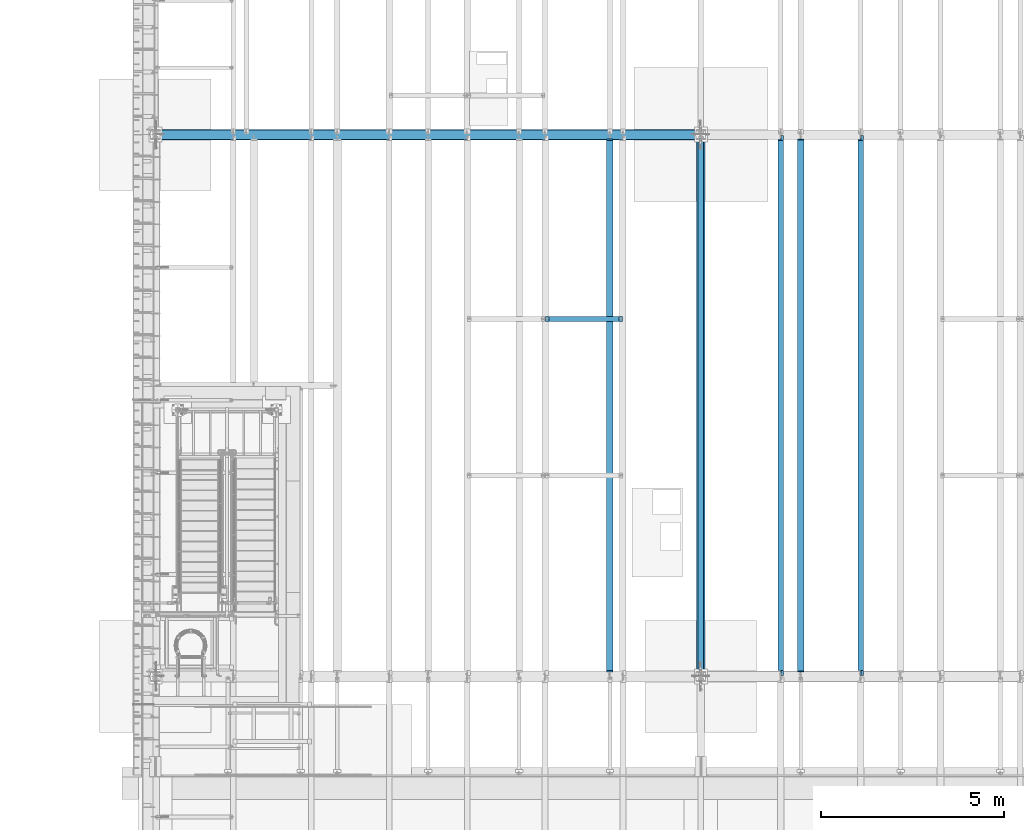
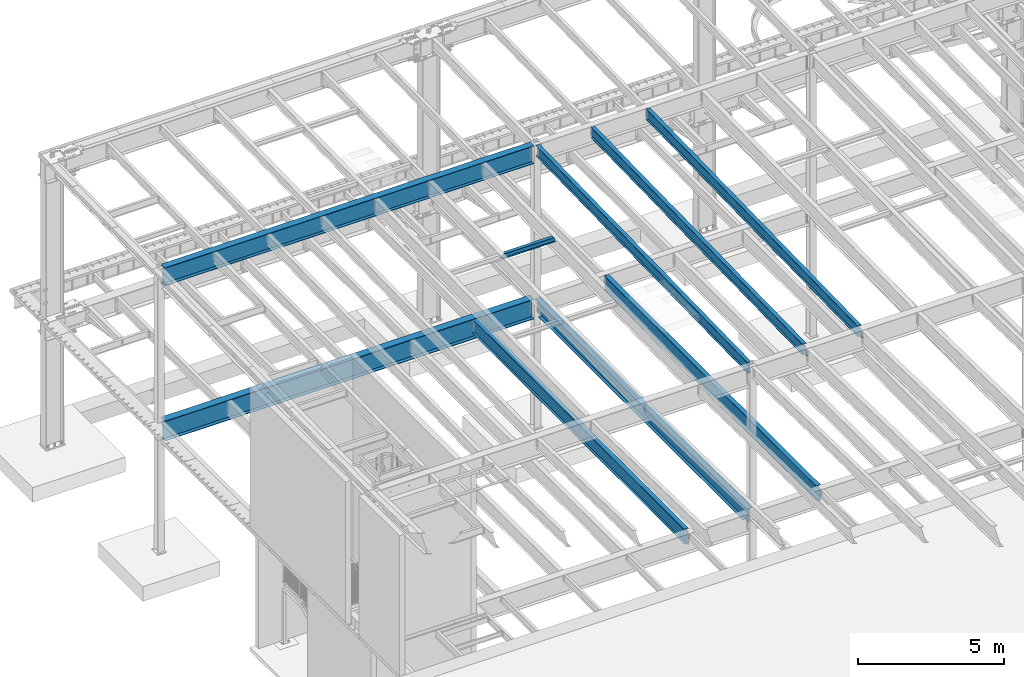
# One storey, part 1098 of 1763: 9 beams, 9 elements without a shape of their own.
"""IFC2X3 building model written with IfcOpenShell, lengths in millimetres."""

from ifc_helpers import new_model, si_unit, frame, origin_with_axes, place, context, subcontext, project, spatial, faceted_brep, material, type_object, element, aggregate, save


model = new_model("IFC2X3")

# Units and contexts
model_context = context("Model", 3, precision=1e-05, world=origin_with_axes())
body_context = subcontext(model_context, "Body", "Model", "MODEL_VIEW")
ifc_project = project(units=[si_unit("LENGTHUNIT", "METRE", prefix="MILLI"), si_unit("AREAUNIT", "SQUARE_METRE"), si_unit("VOLUMEUNIT", "CUBIC_METRE"), si_unit("MASSUNIT", "GRAM", prefix="KILO"), si_unit("TIMEUNIT", "SECOND"), si_unit("PLANEANGLEUNIT", "RADIAN"), si_unit("SOLIDANGLEUNIT", "STERADIAN"), si_unit("THERMODYNAMICTEMPERATUREUNIT", "DEGREE_CELSIUS"), si_unit("LUMINOUSINTENSITYUNIT", "LUMEN")], contexts=[model_context])

# Site, building, storey
site_placement = place(None, origin_with_axes())
site = spatial("IfcSite", under=ifc_project, at=site_placement, CompositionType="ELEMENT")
building_placement = place(site_placement, origin_with_axes())
building = spatial("IfcBuilding", under=site, at=building_placement, Name="Undefined", CompositionType="ELEMENT")
storey_placement = place(building_placement, origin_with_axes())
storey = spatial("IfcBuildingStorey", under=building, at=storey_placement, Name="Undefined", CompositionType="ELEMENT", Elevation=0.0)

# Assembly, beam
assembly_1_placement = place(storey_placement, origin_with_axes())
assembly_1 = element("IfcElementAssembly", 1, at=assembly_1_placement, inside=storey, Name="BEAM", AssemblyPlace="NOTDEFINED", PredefinedType="RIGID_FRAME")
ifc_material = material(Name="STEEL/A992")
beam_type_1 = type_object("IfcBeamType", Name="W8X18", PredefinedType="NOTDEFINED")
beam_1_placement = place(assembly_1_placement, frame((-76743.7229879841, 39776.4, 11388.9111170495), z_axis=(0.0, 0.0, 1.0), x_axis=(1.0, 0.0, 0.0)))
beam_1 = element("IfcBeam", 2, at=beam_1_placement, type_object=beam_type_1, material=ifc_material, Name="BEAM", ObjectType="W8X18", context=body_context, shape_type="Brep", body=[
    faceted_brep([(2030.05010096592, -3.17500000000018, 68.5472454972532), (2030.05010096592, 3.17500000000018, 68.5472454972532), (2029.18911617418, 3.17500000000291, 69.8358002989789), (2029.18911617418, -3.17500000000291, 69.8358002989789), (2034.17027743408, -3.17500000000018, 65.7942315967757), (2034.17027743408, 3.17500000000018, 65.7942315967757), (2039.03035695212, -3.17500000000018, 64.8275016741882), (2039.03035695212, 3.17500000000018, 64.8275016741882), (2108.88035714286, -3.17500000000018, 64.8275016741882), (2108.88035714286, 3.17500000000018, 64.8275016741882), (2028.46260401768, -3.17500000000291, 70.3212402021363), (2028.46260401768, 3.17500000000291, 70.3212402021363), (2025.7095901172, 3.17500000000291, 74.44141667029), (2025.7095901172, -3.17500000000291, 74.44141667029), (2024.74286019462, 3.17500000000291, 79.3014961883364), (2024.74286019462, -3.17500000000291, 79.3014961883364), (2024.74286019463, 66.6750000000002, 95.25), (2024.74286019463, 3.17500000000018, 95.25), (101.599996948244, 3.17500000000018, 95.25), (101.599996948244, 66.6750000000002, 95.25), (2024.74286019463, -66.6750000000002, 95.25), (2024.74286019463, -66.6750000000002, 103.1875), (101.599996948244, -66.6750000000002, 103.1875), (101.599996948244, -66.6750000000002, 95.25), (2024.74286019463, 66.6750000000002, 103.1875), (101.599996948244, 66.6750000000002, 103.1875), (2024.74286019463, -3.17500000000018, 95.25), (101.599996948244, -3.17500000000018, 95.25), (101.599996948236, 3.17499999999927, 79.301496189446), (101.599996948236, -3.17499999999927, 79.301496189446), (100.633267025652, 3.17499999999927, 74.4414166713996), (100.633267025652, -3.17499999999927, 74.4414166713996), (97.8802531251713, 3.17499999999927, 70.3212402032459), (97.8802531251713, -3.17499999999927, 70.3212402032459), (97.153740969894, 3.17499999999927, 69.8358003008998), (97.153740969894, -3.17499999999927, 69.8358003008998), (96.2927561769247, 3.17500000000018, 68.5472454911378), (96.2927561769247, -3.17500000000018, 68.5472454911378), (92.1725797087711, 3.17500000000018, 65.7942315906603), (92.1725797087711, -3.17500000000018, 65.7942315906603), (87.3125001907247, 3.17500000000018, 64.8275016680727), (87.3125001907247, -3.17500000000018, 64.8275016680727), (17.4624999999905, 3.17500000000018, 64.8275016680727), (17.4624999999905, -3.17500000000018, 64.8275016680727), (17.4624999999905, 3.17500000000018, -95.25), (17.4624999999905, 66.6750000000002, -95.25), (17.4624999999905, 66.6750000000002, -103.1875), (17.4624999999905, -66.6750000000002, -103.1875), (17.4624999999905, -66.6750000000002, -95.25), (17.4624999999905, -3.17500000000018, -95.25), (2108.88035714286, 3.17500000000018, -95.25), (2108.88035714286, 66.6750000000002, -95.25), (2108.88035714286, 66.6750000000002, -103.1875), (2108.88035714286, -66.6750000000002, -103.1875), (2108.88035714286, -66.6750000000002, -95.25), (2108.88035714286, -3.17500000000018, -95.25)], [[[0, 1, 2, 3]], [[4, 5, 1, 0]], [[6, 7, 5, 4]], [[8, 9, 7, 6]], [[10, 11, 12, 13]], [[13, 12, 14, 15]], [[16, 17, 18, 19]], [[20, 21, 22, 23]], [[21, 24, 25, 22]], [[24, 16, 19, 25]], [[21, 20, 26, 15, 14, 17, 16, 24]], [[26, 20, 23, 27]], [[22, 25, 19, 18, 28, 29, 27, 23]], [[29, 28, 30, 31]], [[31, 30, 32, 33]], [[33, 32, 34, 35]], [[35, 34, 36, 37]], [[37, 36, 38, 39]], [[39, 38, 40, 41]], [[41, 40, 42, 43]], [[44, 45, 46, 47, 48, 49, 43, 42]], [[45, 44, 50, 51]], [[46, 45, 51, 52]], [[47, 46, 52, 53]], [[48, 47, 53, 54]], [[49, 48, 54, 55]], [[4, 0, 3, 10, 13, 15, 26, 27, 29, 31, 33, 35, 37, 39, 41, 43, 49, 55, 8, 6]], [[11, 10, 3, 2]], [[50, 44, 42, 40, 38, 36, 34, 32, 30, 28, 18, 17, 14, 12, 11, 2, 1, 5, 7, 9]], [[55, 54, 53, 52, 51, 50, 9, 8]]]),
])
aggregate(assembly_1, [beam_1])

assembly_2_placement = place(storey_placement, origin_with_axes())
assembly_2 = element("IfcElementAssembly", 3, at=assembly_2_placement, inside=storey, Name="BEAM", AssemblyPlace="NOTDEFINED", PredefinedType="RIGID_FRAME")
beam_type_2 = type_object("IfcBeamType", Name="W18X35", PredefinedType="NOTDEFINED")
beam_2_placement = place(assembly_2_placement, frame((-68132.3972736984, 30027.4629676506, 11064.9232324289), z_axis=(0.0, -0.0206852279954837, 0.999786037781472), x_axis=(0.0, 0.999786037781472, 0.0206852279954825)))
beam_2 = element("IfcBeam", 4, at=beam_2_placement, type_object=beam_type_2, material=ifc_material, Name="BEAM", ObjectType="W18X35", context=body_context, shape_type="Brep", body=[
    faceted_brep([(148.534036706205, 4.26867060484074, -214.312499999867), (148.534036706187, 4.26882633028436, -225.424999999857), (10.5200655540102, 4.26881607816904, -225.424999999832), (10.7499793429743, 4.26866036980209, -214.312499999842), (148.534031383831, 76.1999999999971, -214.312499999869), (148.534031383828, 76.1999999999971, -225.424999999857), (161.234030986459, -3.96875, 187.065001487535), (161.234030986459, 3.96875, 187.065001487535), (160.267301063872, 3.96875, 182.204921969502), (160.267301063872, -3.96875, 182.204921969502), (157.514287163402, 3.96875, 178.084745501357), (157.514287163402, -3.96875, 178.084745501357), (153.394110695255, 3.96875, 175.331731600885), (153.394110695255, -3.96875, 175.331731600885), (148.534031177223, 3.96875, 174.365001678299), (148.534031177223, -3.96875, 174.365001678299), (18.7915826811914, 3.96875, 174.365001678325), (18.7915826811914, -3.96875, 174.365001678325), (10.7499793429743, -3.96875, -214.312499999842), (14757.8115434472, -3.96875, -214.312500002648), (14765.8531467846, -3.96875, 174.36500163611), (14641.5955948759, -3.96875, 174.365001636133), (14636.7355153579, -3.96875, 175.331731558719), (14632.6153388897, -3.96875, 178.084745459191), (14629.8623249892, -3.96875, 182.204921927336), (14628.8955950666, -3.96875, 187.065001445368), (14628.8955950666, -3.96875, 214.312499997053), (161.234030986467, -3.96875, 214.312499999809), (10.7499793429743, -76.1999999999971, -214.312499999842), (14757.8115434472, -76.1999999999971, -214.312500002648), (10.5200655540102, -76.1999999999971, -225.424999999832), (14757.5816296582, -76.1999999999971, -225.425000002639), (14641.5955921487, 4.26882640406257, -214.312500002627), (14641.5955921487, 4.26867068048159, -225.425000002617), (14641.5955830855, 76.1999999999971, -225.425000002617), (14641.5955830855, 76.1999999999971, -214.312500002628), (14757.8115434472, 4.26884104704368, -214.312500002648), (14757.5816296582, 4.26868529446074, -225.425000002639), (14757.8115434472, 3.96875, -214.312500002648), (14765.8531467846, 3.96875, 174.36500163611), (14641.5955948759, 3.96875, 174.365001636133), (14636.7355153579, 3.96875, 175.331731558719), (14632.6153388897, 3.96875, 178.084745459191), (14629.8623249892, 3.96875, 182.204921927336), (14628.8955950666, 3.96875, 187.065001445368), (14628.8955950666, -76.1999999999971, 225.424999997045), (14628.8955950666, -76.1999999999971, 214.312499997053), (14628.8955950666, 3.96875, 214.312499997053), (14628.8955950666, 76.1999999999971, 214.312499997053), (14628.8955950666, 76.1999999999971, 225.424999997045), (161.234030986467, 3.96875, 214.312499999809), (161.234030986467, 76.1999999999971, 214.312499999809), (161.23403098647, 76.1999999999971, 225.424999999799), (161.23403098647, -76.1999999999971, 225.424999999799), (161.234030986467, -76.1999999999971, 214.312499999809), (10.7499793429743, 3.96875, -214.312499999842)], [[[0, 1, 2, 3]], [[4, 5, 1, 0]], [[6, 7, 8, 9]], [[9, 8, 10, 11]], [[11, 10, 12, 13]], [[13, 12, 14, 15]], [[15, 14, 16, 17]], [[9, 11, 13, 15, 17, 18, 19, 20, 21, 22, 23, 24, 25, 26, 27, 6]], [[18, 28, 29, 19]], [[28, 30, 31, 29]], [[32, 33, 34, 35]], [[36, 37, 33, 32]], [[38, 39, 20, 19, 29, 31, 37, 36]], [[20, 39, 40, 21]], [[21, 40, 41, 22]], [[22, 41, 42, 23]], [[23, 42, 43, 24]], [[24, 43, 44, 25]], [[45, 46, 26, 25, 44, 47, 48, 49]], [[48, 47, 50, 51]], [[49, 48, 51, 52]], [[45, 49, 52, 53]], [[46, 45, 53, 54]], [[26, 46, 54, 27]], [[53, 52, 51, 50, 7, 6, 27, 54]], [[47, 44, 43, 42, 41, 40, 39, 38, 55, 16, 14, 12, 10, 8, 7, 50]], [[30, 28, 18, 17, 16, 55, 3, 2]], [[34, 33, 37, 31, 30, 2, 1, 5]], [[35, 34, 5, 4]], [[55, 38, 36, 32, 35, 4, 0, 3]]]),
])
aggregate(assembly_2, [beam_2])

assembly_3_placement = place(storey_placement, origin_with_axes())
assembly_3 = element("IfcElementAssembly", 5, at=assembly_3_placement, inside=storey, Name="BEAM", AssemblyPlace="NOTDEFINED", PredefinedType="RIGID_FRAME")
beam_3_placement = place(assembly_3_placement, frame((-70311.7172736983, 30027.4629676506, 11064.9232324289), z_axis=(0.0, -0.0206852279954837, 0.999786037781472), x_axis=(0.0, 0.999786037781472, 0.0206852279954825)))
beam_3 = element("IfcBeam", 6, at=beam_3_placement, type_object=beam_type_2, material=ifc_material, Name="BEAM", ObjectType="W18X35", context=body_context, shape_type="Brep", body=[
    faceted_brep([(161.234036217043, 4.26867060289806, -214.312499999869), (161.234036217025, 4.26882632687921, -225.424999999863), (10.5200655540102, 4.26881607816904, -225.424999999832), (10.7499793429743, 4.26866036980209, -214.312499999842), (161.234031325755, 76.1999999999971, -214.312499999867), (161.234031325748, 76.1999999999971, -225.424999999861), (161.234030986459, -3.96875, 187.065001487535), (161.234030986459, 3.96875, 187.065001487535), (160.267301063872, 3.96875, 182.204921969502), (160.267301063872, -3.96875, 182.204921969502), (157.514287163402, 3.96875, 178.084745501357), (157.514287163402, -3.96875, 178.084745501357), (153.394110695255, 3.96875, 175.331731600885), (153.394110695255, -3.96875, 175.331731600885), (148.534031177223, 3.96875, 174.365001678299), (148.534031177223, -3.96875, 174.365001678299), (18.7915826811914, 3.96875, 174.365001678325), (18.7915826811914, -3.96875, 174.365001678325), (10.7499793429743, -3.96875, -214.312499999842), (14757.8115434472, -3.96875, -214.312500002648), (14765.8531467846, -3.96875, 174.36500163611), (14641.5955948759, -3.96875, 174.365001636133), (14636.7355153579, -3.96875, 175.331731558719), (14632.6153388897, -3.96875, 178.084745459191), (14629.8623249892, -3.96875, 182.204921927336), (14628.8955950666, -3.96875, 187.065001445368), (14628.8955950666, -3.96875, 214.312499997053), (161.234030986467, -3.96875, 214.312499999809), (10.7499793429743, -76.1999999999971, -214.312499999842), (14757.8115434472, -76.1999999999971, -214.312500002648), (10.5200655540102, -76.1999999999971, -225.424999999832), (14757.5816296582, -76.1999999999971, -225.425000002639), (14641.5955921487, 4.26882640406257, -214.312500002627), (14641.5955921487, 4.26867068048159, -225.425000002617), (14641.5955830855, 76.1999999999971, -225.425000002617), (14641.5955830855, 76.1999999999971, -214.312500002628), (14757.8115434472, 4.26884104704368, -214.312500002648), (14757.5816296582, 4.26868529446074, -225.425000002639), (14757.8115434472, 3.96875, -214.312500002648), (14765.8531467846, 3.96875, 174.36500163611), (14641.5955948759, 3.96875, 174.365001636133), (14636.7355153579, 3.96875, 175.331731558719), (14632.6153388897, 3.96875, 178.084745459191), (14629.8623249892, 3.96875, 182.204921927336), (14628.8955950666, 3.96875, 187.065001445368), (14628.8955950666, -76.1999999999971, 225.424999997045), (14628.8955950666, -76.1999999999971, 214.312499997053), (14628.8955950666, 3.96875, 214.312499997053), (14628.8955950666, 76.1999999999971, 214.312499997053), (14628.8955950666, 76.1999999999971, 225.424999997045), (161.234030986467, 3.96875, 214.312499999809), (161.234030986467, 76.1999999999971, 214.312499999809), (161.23403098647, 76.1999999999971, 225.424999999799), (161.23403098647, -76.1999999999971, 225.424999999799), (161.234030986467, -76.1999999999971, 214.312499999809), (10.7499793429743, 3.96875, -214.312499999842)], [[[0, 1, 2, 3]], [[4, 5, 1, 0]], [[6, 7, 8, 9]], [[9, 8, 10, 11]], [[11, 10, 12, 13]], [[13, 12, 14, 15]], [[15, 14, 16, 17]], [[9, 11, 13, 15, 17, 18, 19, 20, 21, 22, 23, 24, 25, 26, 27, 6]], [[18, 28, 29, 19]], [[28, 30, 31, 29]], [[32, 33, 34, 35]], [[36, 37, 33, 32]], [[38, 39, 20, 19, 29, 31, 37, 36]], [[20, 39, 40, 21]], [[21, 40, 41, 22]], [[22, 41, 42, 23]], [[23, 42, 43, 24]], [[24, 43, 44, 25]], [[45, 46, 26, 25, 44, 47, 48, 49]], [[48, 47, 50, 51]], [[49, 48, 51, 52]], [[45, 49, 52, 53]], [[46, 45, 53, 54]], [[26, 46, 54, 27]], [[53, 52, 51, 50, 7, 6, 27, 54]], [[47, 44, 43, 42, 41, 40, 39, 38, 55, 16, 14, 12, 10, 8, 7, 50]], [[30, 28, 18, 17, 16, 55, 3, 2]], [[34, 33, 37, 31, 30, 2, 1, 5]], [[35, 34, 5, 4]], [[55, 38, 36, 32, 35, 4, 0, 3]]]),
])
aggregate(assembly_3, [beam_3])

assembly_4_placement = place(storey_placement, origin_with_axes())
assembly_4 = element("IfcElementAssembly", 7, at=assembly_4_placement, inside=storey, Name="BEAM", AssemblyPlace="NOTDEFINED", PredefinedType="RIGID_FRAME")
beam_4_placement = place(assembly_4_placement, frame((-72491.0372736984, 30027.4629676506, 11064.9232324289), z_axis=(0.0, -0.0206852279954837, 0.999786037781472), x_axis=(0.0, 0.999786037781472, 0.0206852279954825)))
beam_4 = element("IfcBeam", 8, at=beam_4_placement, type_object=beam_type_2, material=ifc_material, Name="BEAM", ObjectType="W18X35", context=body_context, shape_type="Brep", body=[
    faceted_brep([(135.16548513544, -76.1999999999971, -225.424999999856), (135.16548513544, 76.1999999999971, -225.424999999856), (14632.1422904328, 76.1999999999971, -225.425000002615), (14632.1422904328, -76.1999999999971, -225.425000002615), (135.395398924404, -76.1999999999971, -214.312499999864), (135.395398924404, -3.96875, -214.312499999864), (144.263502213013, -3.96875, 214.312499999811), (144.263502213013, -76.1999999999971, 214.312499999811), (144.493416001977, -76.1999999999971, 225.424999999803), (144.493416001977, 76.1999999999971, 225.424999999803), (144.263502213013, 76.1999999999971, 214.312499999811), (144.263502213013, 3.96875, 214.312499999811), (135.395398924404, 3.96875, -214.312499999864), (135.395398924404, 76.1999999999971, -214.312499999864), (14632.3722042217, -76.1999999999971, -214.312500002625), (14632.3722042217, -3.96875, -214.312500002625), (14641.2403075104, -3.96875, 214.312499997051), (14641.2403075104, -76.1999999999971, 214.312499997051), (14641.4702212993, -76.1999999999971, 225.424999997043), (14641.4702212993, 76.1999999999971, 225.424999997043), (14641.2403075104, 76.1999999999971, 214.312499997051), (14641.2403075104, 3.96875, 214.312499997051), (14632.3722042217, 3.96875, -214.312500002625), (14632.3722042217, 76.1999999999971, -214.312500002625)], [[[0, 1, 2, 3]], [[0, 4, 5, 6, 7, 8, 9, 10, 11, 12, 13, 1]], [[5, 4, 14, 15]], [[6, 5, 15, 16]], [[7, 6, 16, 17]], [[8, 7, 17, 18]], [[9, 8, 18, 19]], [[10, 9, 19, 20]], [[11, 10, 20, 21]], [[12, 11, 21, 22]], [[13, 12, 22, 23]], [[1, 13, 23, 2]], [[22, 21, 20, 19, 18, 17, 16, 15, 14, 3, 2, 23]], [[4, 0, 3, 14]]]),
])
aggregate(assembly_4, [beam_4])

assembly_5_placement = place(storey_placement, origin_with_axes())
assembly_5 = element("IfcElementAssembly", 9, at=assembly_5_placement, inside=storey, Name="BEAM", AssemblyPlace="NOTDEFINED", PredefinedType="RIGID_FRAME")
beam_type_3 = type_object("IfcBeamType", Name="W24X55", PredefinedType="NOTDEFINED")
beam_5_placement = place(assembly_5_placement, frame((-74971.7706070317, 30022.8, 4894.2625), z_axis=(0.0, 0.0, 1.0), x_axis=(0.0, 1.0, 0.0)))
beam_5 = element("IfcBeam", 10, at=beam_5_placement, type_object=beam_type_3, material=ifc_material, Name="BEAM", ObjectType="W24X55", context=body_context, shape_type="Brep", body=[
    faceted_brep([(19.8437500000036, -5.06263076800678, -287.3375), (19.8437500000036, -5.06239138569799, -300.0375), (121.443760724065, -5.06237878766842, -300.0375), (121.443760724113, -5.06261816997721, -287.3375), (121.443815955325, -88.9000000000015, -287.3375), (121.443815955325, -88.9000000000015, -300.0375), (159.543750000004, -4.76249999999709, 280.727501487732), (159.543750000004, 4.76249999999709, 280.727501487732), (158.577020077417, 4.76249999999709, 275.867421969687), (158.577020077417, -4.76249999999709, 275.867421969687), (155.824006176939, 4.76249999999709, 271.747245501533), (155.824006176939, -4.76249999999709, 271.747245501533), (151.703829708786, 4.76249999999709, 268.994231601055), (151.703829708786, -4.76249999999709, 268.994231601055), (146.843750190739, 4.76249999999709, 268.027501678467), (146.843750190739, -4.76249999999709, 268.027501678467), (19.8437500000036, 4.76249999999709, 268.027501678467), (19.8437500000036, -4.76249999999709, 268.027501678467), (19.84375, -4.76249999999709, -287.3375), (14762.95625, -4.76249999999709, -287.3375), (14762.95625, -4.76249999999709, 268.027501678467), (14635.9562498093, -4.76249999999709, 268.027501678467), (14631.0961702912, -4.76249999999709, 268.994231601055), (14626.9759938231, -4.76249999999709, 271.747245501533), (14624.2229799226, -4.76249999999709, 275.867421969687), (14623.25625, -4.76249999999709, 280.727501487732), (14623.25625, -4.76249999999709, 287.3375), (159.543750000004, -4.76249999999709, 287.3375), (14762.95625, 4.76249999999709, 268.027501678467), (14635.9562498093, 4.76249999999709, 268.027501678467), (14631.0961702912, 4.76249999999709, 268.994231601055), (14626.9759938231, 4.76249999999709, 271.747245501533), (14624.2229799226, 4.76249999999709, 275.867421969687), (14623.25625, 4.76249999999709, 280.727501487732), (14623.25625, -88.8999999999942, 300.0375), (14623.25625, -88.8999999999942, 287.3375), (14623.25625, 4.76249999999709, 287.3375), (14623.25625, 88.8999999999942, 287.3375), (14623.25625, 88.8999999999942, 300.0375), (159.543750000004, 4.76249999999709, 287.3375), (159.543750000004, 88.8999999999942, 287.3375), (159.543750000004, 88.8999999999942, 300.0375), (159.543750000004, -88.8999999999942, 300.0375), (159.543750000004, -88.8999999999942, 287.3375), (14762.95625, 4.76249999999709, -287.3375), (19.84375, 4.76249999999709, -287.3375), (14762.95625, 5.0626307680941, -287.3375), (14661.3562392746, 5.06261817002087, -287.3375), (14661.356228879, 88.8999999999942, -287.3375), (121.443751839222, 88.9000000000015, -287.3375), (121.443761016704, 5.06237876559317, -287.3375), (19.8437500000036, 5.06236616715614, -287.3375), (121.443761016661, 5.06261814791651, -300.0375), (19.8437500000036, 5.06260554946493, -300.0375), (121.443751839222, 88.9000000000015, -300.0375), (14661.356228879, 88.8999999999942, -300.0375), (14661.3562392746, 5.06237878771208, -300.0375), (14762.95625, 5.0623913857853, -300.0375), (14762.95625, -5.06236616667593, -287.3375), (14762.95625, -5.06260554897017, -300.0375), (14661.3562389844, -5.0623787647346, -287.3375), (14661.3562389844, -5.06261814705795, -300.0375), (14661.3562493798, -88.8999999999942, -287.3375), (14661.3562493798, -88.8999999999942, -300.0375)], [[[0, 1, 2, 3]], [[4, 3, 2, 5]], [[6, 7, 8, 9]], [[9, 8, 10, 11]], [[11, 10, 12, 13]], [[13, 12, 14, 15]], [[15, 14, 16, 17]], [[9, 11, 13, 15, 17, 18, 19, 20, 21, 22, 23, 24, 25, 26, 27, 6]], [[20, 28, 29, 21]], [[21, 29, 30, 22]], [[22, 30, 31, 23]], [[23, 31, 32, 24]], [[24, 32, 33, 25]], [[34, 35, 26, 25, 33, 36, 37, 38]], [[37, 36, 39, 40]], [[38, 37, 40, 41]], [[34, 38, 41, 42]], [[35, 34, 42, 43]], [[26, 35, 43, 27]], [[42, 41, 40, 39, 7, 6, 27, 43]], [[36, 33, 32, 31, 30, 29, 28, 44, 45, 16, 14, 12, 10, 8, 7, 39]], [[45, 44, 46, 47, 48, 49, 50, 51]], [[50, 52, 53, 51]], [[49, 54, 52, 50]], [[48, 55, 54, 49]], [[47, 56, 55, 48]], [[46, 57, 56, 47]], [[44, 28, 20, 19, 58, 59, 57, 46]], [[58, 60, 61, 59]], [[62, 63, 61, 60]], [[63, 62, 4, 5]], [[1, 53, 52, 54, 55, 56, 57, 59, 61, 63, 5, 2]], [[18, 17, 16, 45, 51, 53, 1, 0]], [[62, 60, 58, 19, 18, 0, 3, 4]]]),
])
aggregate(assembly_5, [beam_5])

assembly_6_placement = place(storey_placement, origin_with_axes())
assembly_6 = element("IfcElementAssembly", 11, at=assembly_6_placement, inside=storey, Name="BEAM", AssemblyPlace="NOTDEFINED", PredefinedType="RIGID_FRAME")
beam_6_placement = place(assembly_6_placement, frame((-69766.8872736983, 30022.8, 4894.2625), z_axis=(0.0, 0.0, 1.0), x_axis=(0.0, 1.0, 0.0)))
beam_6 = element("IfcBeam", 12, at=beam_6_placement, type_object=beam_type_3, material=ifc_material, Name="BEAM", ObjectType="W24X55", context=body_context, shape_type="Brep", body=[
    faceted_brep([(19.0499999999993, -5.06263026501983, -287.3375), (19.0499999999993, -5.06239088271832, -300.0375), (120.650010238503, -5.06237879249238, -300.0375), (120.650010238547, -5.06261817480845, -287.3375), (120.650020215031, -88.9000000000015, -287.3375), (120.650020215031, -88.9000000000015, -300.0375), (146.049999999999, -4.76249999999709, 280.727501487732), (146.049999999999, 4.76249999999709, 280.727501487732), (145.083270077412, 4.76249999999709, 275.867421969687), (145.083270077412, -4.76249999999709, 275.867421969687), (142.330256176934, 4.76249999999709, 271.747245501533), (142.330256176934, -4.76249999999709, 271.747245501533), (138.210079708781, 4.76249999999709, 268.994231601055), (138.210079708781, -4.76249999999709, 268.994231601055), (133.350000190734, 4.76249999999709, 268.027501678467), (133.350000190734, -4.76249999999709, 268.027501678467), (19.0499999999993, 4.76249999999709, 268.027501678467), (19.0499999999993, -4.76249999999709, 268.027501678467), (19.0499999999993, -4.76249999999709, -287.3375), (14763.75, -4.76249999999709, -287.3375), (14763.75, -4.76249999999709, 268.027501678466), (14649.4499998093, -4.76249999999709, 268.027501678466), (14644.5899202912, -4.76249999999709, 268.994231601054), (14640.4697438231, -4.76249999999709, 271.747245501532), (14637.7167299226, -4.76249999999709, 275.867421969686), (14636.75, -4.76249999999709, 280.727501487731), (14636.75, -4.76249999999709, 287.3375), (146.049999999999, -4.76249999999709, 287.3375), (14763.75, 4.76249999999709, 268.027501678466), (14649.4499998093, 4.76249999999709, 268.027501678466), (14644.5899202912, 4.76249999999709, 268.994231601054), (14640.4697438231, 4.76249999999709, 271.747245501532), (14637.7167299226, 4.76249999999709, 275.867421969686), (14636.75, 4.76249999999709, 280.727501487731), (14636.75, -88.9000000000015, 300.0375), (14636.75, -88.9000000000015, 287.3375), (14636.75, 4.76249999999709, 287.3375), (14636.75, 88.9000000000015, 287.3375), (14636.75, 88.9000000000015, 300.0375), (146.049999999999, 4.76249999999709, 287.3375), (146.049999999999, 88.9000000000015, 287.3375), (146.049999999999, 88.9000000000015, 300.0375), (146.049999999999, -88.9000000000015, 300.0375), (146.049999999999, -88.9000000000015, 287.3375), (14763.75, 4.76249999999709, -287.3375), (19.0499999999993, 4.76249999999709, -287.3375), (14763.75, 5.06263026504894, -287.3375), (14662.1499897615, 5.06261817483755, -287.3375), (14662.1499797849, 88.9000000000015, -287.3375), (120.650000595357, 88.9000000000015, -287.3375), (120.650010572102, 5.06237876442901, -287.3375), (19.0499999999993, 5.06236667421763, -287.3375), (120.650010572055, 5.06261814674508, -300.0375), (19.0499999999993, 5.06260605652642, -300.0375), (120.650000595357, 88.9000000000015, -300.0375), (14662.1499797849, 88.9000000000015, -300.0375), (14662.1499897615, 5.06237879252149, -300.0375), (14763.75, 5.06239088274742, -300.0375), (14763.75, -5.06236667417397, -287.3375), (14763.75, -5.06260605648276, -300.0375), (14662.1499894279, -5.06237876438536, -287.3375), (14662.1499894279, -5.06261814670142, -300.0375), (14662.1499994046, -88.9000000000015, -287.3375), (14662.1499994046, -88.9000000000015, -300.0375)], [[[0, 1, 2, 3]], [[4, 3, 2, 5]], [[6, 7, 8, 9]], [[9, 8, 10, 11]], [[11, 10, 12, 13]], [[13, 12, 14, 15]], [[15, 14, 16, 17]], [[9, 11, 13, 15, 17, 18, 19, 20, 21, 22, 23, 24, 25, 26, 27, 6]], [[20, 28, 29, 21]], [[21, 29, 30, 22]], [[22, 30, 31, 23]], [[23, 31, 32, 24]], [[24, 32, 33, 25]], [[34, 35, 26, 25, 33, 36, 37, 38]], [[37, 36, 39, 40]], [[38, 37, 40, 41]], [[34, 38, 41, 42]], [[35, 34, 42, 43]], [[26, 35, 43, 27]], [[42, 41, 40, 39, 7, 6, 27, 43]], [[36, 33, 32, 31, 30, 29, 28, 44, 45, 16, 14, 12, 10, 8, 7, 39]], [[45, 44, 46, 47, 48, 49, 50, 51]], [[50, 52, 53, 51]], [[49, 54, 52, 50]], [[48, 55, 54, 49]], [[47, 56, 55, 48]], [[46, 57, 56, 47]], [[44, 28, 20, 19, 58, 59, 57, 46]], [[58, 60, 61, 59]], [[62, 63, 61, 60]], [[63, 62, 4, 5]], [[1, 53, 52, 54, 55, 56, 57, 59, 61, 63, 5, 2]], [[18, 17, 16, 45, 51, 53, 1, 0]], [[62, 60, 58, 19, 18, 0, 3, 4]]]),
])
aggregate(assembly_6, [beam_6])

assembly_7_placement = place(storey_placement, origin_with_axes())
assembly_7 = element("IfcElementAssembly", 13, at=assembly_7_placement, inside=storey, Name="BEAM", AssemblyPlace="NOTDEFINED", PredefinedType="RIGID_FRAME")
beam_type_4 = type_object("IfcBeamType", Name="W33X118", PredefinedType="NOTDEFINED")
beam_7_placement = place(assembly_7_placement, frame((-87375.4372736983, 44805.6, 4776.7875), z_axis=(0.0, 0.0, 1.0), x_axis=(1.0, 0.0, 0.0)))
beam_7 = element("IfcBeam", 14, at=beam_7_placement, type_object=beam_type_4, material=ifc_material, Name="BEAM", ObjectType="W33X118", context=body_context, shape_type="Brep", body=[
    faceted_brep([(141.287499999999, 146.049999999999, -417.512500000001), (141.287499999999, 146.049999999999, -398.4625), (14743.1125, 146.049999999999, -398.4625), (14743.1125, 146.050000000003, -417.5125), (141.287499999999, 7.14374999999927, -398.4625), (14743.1125, 7.14374999999927, -398.4625), (141.287499999999, 7.14374999999927, 398.4625), (14743.1125, 7.14374999999927, 398.4625), (141.287499999999, 146.049999999999, 398.4625), (14743.1125, 146.049999999999, 398.4625), (141.287499999999, 146.049999999999, 417.512500000001), (14743.1125, 146.050000000003, 417.5125), (141.287499999999, -146.049999999999, 417.512500000001), (14743.1125, -146.050000000003, 417.5125), (141.287499999999, -146.049999999999, 398.4625), (14743.1125, -146.049999999999, 398.4625), (141.287499999999, -7.14374999999927, 398.4625), (14743.1125, -7.14374999999927, 398.4625), (141.287499999999, -7.14374999999927, -398.4625), (14743.1125, -7.14374999999927, -398.4625), (141.287499999999, -146.049999999999, -398.4625), (14743.1125, -146.049999999999, -398.4625), (141.287499999999, -146.049999999999, -417.512500000001), (14743.1125, -146.050000000003, -417.5125)], [[[0, 1, 2, 3]], [[1, 4, 5, 2]], [[4, 6, 7, 5]], [[6, 8, 9, 7]], [[8, 10, 11, 9]], [[10, 12, 13, 11]], [[12, 14, 15, 13]], [[14, 16, 17, 15]], [[16, 18, 19, 17]], [[18, 20, 21, 19]], [[20, 22, 23, 21]], [[22, 0, 3, 23]], [[5, 7, 9, 11, 13, 15, 17, 19, 21, 23, 3, 2]], [[22, 20, 18, 16, 14, 12, 10, 8, 6, 4, 1, 0]]]),
])
aggregate(assembly_7, [beam_7])

assembly_8_placement = place(storey_placement, origin_with_axes())
assembly_8 = element("IfcElementAssembly", 15, at=assembly_8_placement, inside=storey, Name="BEAM", AssemblyPlace="NOTDEFINED", PredefinedType="RIGID_FRAME")
beam_type_5 = type_object("IfcBeamType", Name="W30X99", PredefinedType="NOTDEFINED")
beam_8_placement = place(assembly_8_placement, frame((-87375.4372736983, 44805.5999999732, 11218.9213409688), z_axis=(0.0, 0.0, 1.0), x_axis=(1.0, 0.0, 0.0)))
beam_8 = element("IfcBeam", 16, at=beam_8_placement, type_object=beam_type_5, material=ifc_material, Name="BEAM", ObjectType="W30X99", context=body_context, shape_type="Brep", body=[
    faceted_brep([(141.287499999999, 133.349999999999, -376.237499999999), (141.287499999999, 133.349999999999, -358.775), (14743.1125, 133.349999999999, -358.775), (14743.1125, 133.349999999999, -376.237499999999), (141.287500000006, 6.34999999999854, -358.775), (14743.1125, 6.34999999999854, -358.775), (141.287500000006, 6.34999999999854, 358.775), (14743.1125, 6.34999999999854, 358.775), (141.287499999999, 133.349999999999, 358.775), (14743.1125, 133.349999999999, 358.775), (141.287499999999, 133.349999999999, 376.237499999999), (14743.1125, 133.349999999999, 376.237499999999), (141.287499999999, -133.349999999999, 376.237499999999), (14743.1125, -133.349999999999, 376.237499999999), (141.287499999999, -133.349999999999, 358.775), (14743.1125, -133.349999999999, 358.775), (141.287500000006, -6.34999999999854, 358.775), (14743.1125, -6.34999999999854, 358.775), (141.287500000006, -6.34999999999854, -358.775), (14743.1125, -6.34999999999854, -358.775), (141.287499999999, -133.349999999999, -358.775), (14743.1125, -133.349999999999, -358.775), (141.287499999999, -133.349999999999, -376.237499999999), (14743.1125, -133.349999999999, -376.237499999999)], [[[0, 1, 2, 3]], [[1, 4, 5, 2]], [[4, 6, 7, 5]], [[6, 8, 9, 7]], [[8, 10, 11, 9]], [[10, 12, 13, 11]], [[12, 14, 15, 13]], [[14, 16, 17, 15]], [[16, 18, 19, 17]], [[18, 20, 21, 19]], [[20, 22, 23, 21]], [[22, 0, 3, 23]], [[5, 7, 9, 11, 13, 15, 17, 19, 21, 23, 3, 2]], [[22, 20, 18, 16, 14, 12, 10, 8, 6, 4, 1, 0]]]),
])
aggregate(assembly_8, [beam_8])

assembly_9_placement = place(storey_placement, origin_with_axes())
assembly_9 = element("IfcElementAssembly", 17, at=assembly_9_placement, inside=storey, Name="BEAM", AssemblyPlace="NOTDEFINED", PredefinedType="RIGID_FRAME")
beam_type_6 = type_object("IfcBeamType", Name="W24X84", PredefinedType="NOTDEFINED")
beam_9_placement = place(assembly_9_placement, frame((-72491.0372736984, 30022.8, 4887.9125), z_axis=(0.0, 0.0, 1.0), x_axis=(0.0, 1.0, 0.0)))
beam_9 = element("IfcBeam", 18, at=beam_9_placement, type_object=beam_type_6, material=ifc_material, Name="BEAM", ObjectType="W24X84", context=body_context, shape_type="Brep", body=[
    faceted_brep([(144.462500000001, -6.65027077648119, -287.3375), (144.462500000001, -6.64991989452392, -306.3875), (398.462548051273, -6.64982312094799, -306.3875), (398.462548051411, -6.65017400289071, -287.3375), (398.462589065799, -114.300000000003, -287.3375), (398.462589065799, -114.300000000003, -306.3875), (144.462500000001, -6.34999999999854, 287.3375), (144.462500000001, -6.34999999999854, -287.3375), (14638.3375, -6.34999999999854, -287.3375), (14638.3375, -6.34999999999854, 287.3375), (144.462500000001, -114.300000000003, 287.3375), (14638.3375, -114.300000000003, 287.3375), (144.462500000001, -114.300000000003, 306.3875), (14638.3375, -114.300000000003, 306.3875), (144.462500000001, 114.300000000003, 306.3875), (14638.3375, 114.300000000003, 306.3875), (144.462500000001, 114.300000000003, 287.3375), (14638.3375, 114.300000000003, 287.3375), (144.462500000001, 6.34999999999854, 287.3375), (14638.3375, 6.34999999999854, 287.3375), (144.462500000001, 6.34999999999854, -287.3375), (14638.3375, 6.34999999999854, -287.3375), (14638.3375, 6.65027077697596, -287.3375), (14384.3374519492, 6.65017400338547, -287.3375), (14384.3374109348, 114.300000000003, -287.3375), (398.462501906062, 114.300000000003, -287.3375), (398.462542919809, 6.64982301944838, -287.3375), (144.462500000001, 6.64972624585062, -287.3375), (398.462542919671, 6.65017390138382, -306.3875), (144.462500000001, 6.65007712780789, -306.3875), (398.462501906062, 114.300000000003, -306.3875), (14384.3374109348, 114.300000000003, -306.3875), (14384.3374519493, 6.64982312144275, -306.3875), (14638.3375, 6.64991989501868, -306.3875), (14638.3375, -6.64972624439542, -287.3375), (14638.3375, -6.6500771263527, -306.3875), (14384.337457085, -6.64982301799319, -287.3375), (14384.3374570851, -6.65017389992863, -306.3875), (14384.3374980991, -114.300000000003, -287.3375), (14384.3374980991, -114.300000000003, -306.3875)], [[[0, 1, 2, 3]], [[4, 3, 2, 5]], [[6, 7, 8, 9]], [[10, 6, 9, 11]], [[12, 10, 11, 13]], [[14, 12, 13, 15]], [[16, 14, 15, 17]], [[18, 16, 17, 19]], [[20, 18, 19, 21]], [[20, 21, 22, 23, 24, 25, 26, 27]], [[26, 28, 29, 27]], [[25, 30, 28, 26]], [[24, 31, 30, 25]], [[23, 32, 31, 24]], [[22, 33, 32, 23]], [[21, 19, 17, 15, 13, 11, 9, 8, 34, 35, 33, 22]], [[34, 36, 37, 35]], [[38, 39, 37, 36]], [[39, 38, 4, 5]], [[1, 29, 28, 30, 31, 32, 33, 35, 37, 39, 5, 2]], [[7, 6, 10, 12, 14, 16, 18, 20, 27, 29, 1, 0]], [[38, 36, 34, 8, 7, 0, 3, 4]]]),
])
aggregate(assembly_9, [beam_9])

save(model, "model.ifc")
